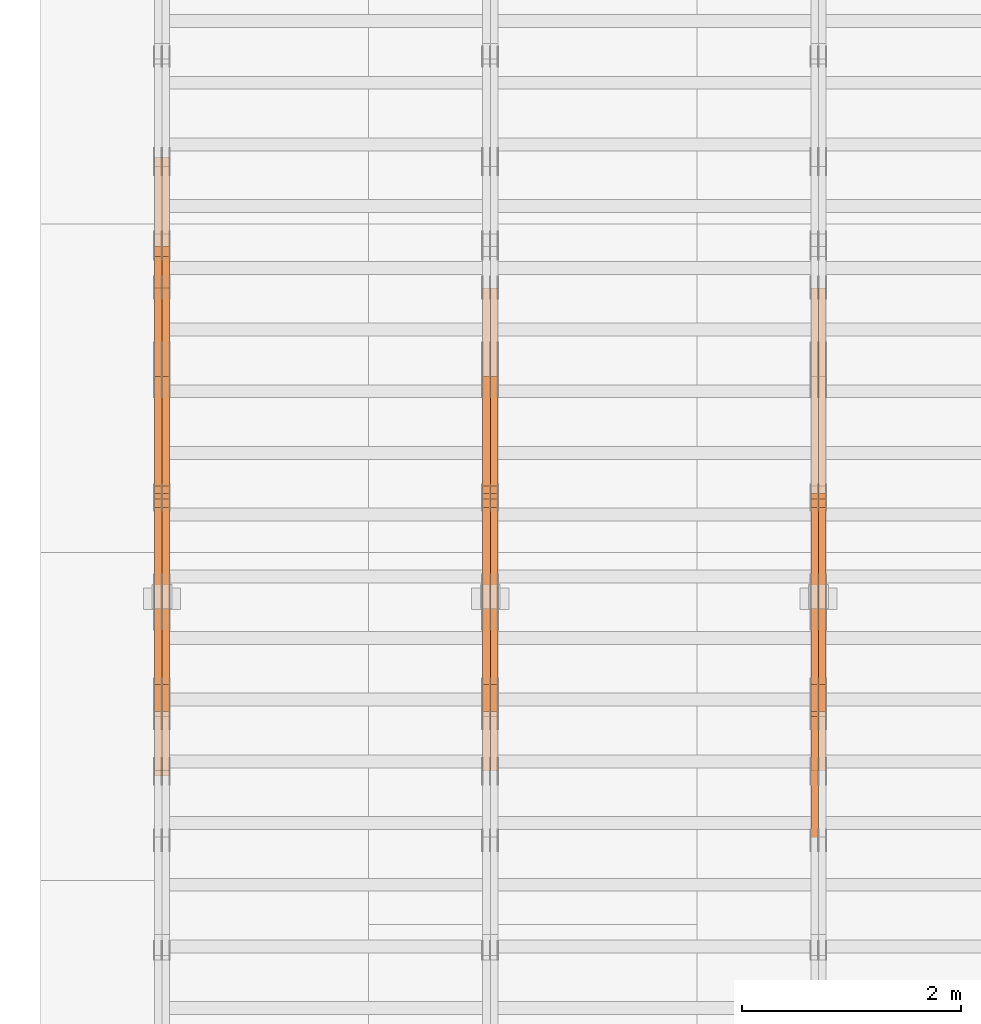
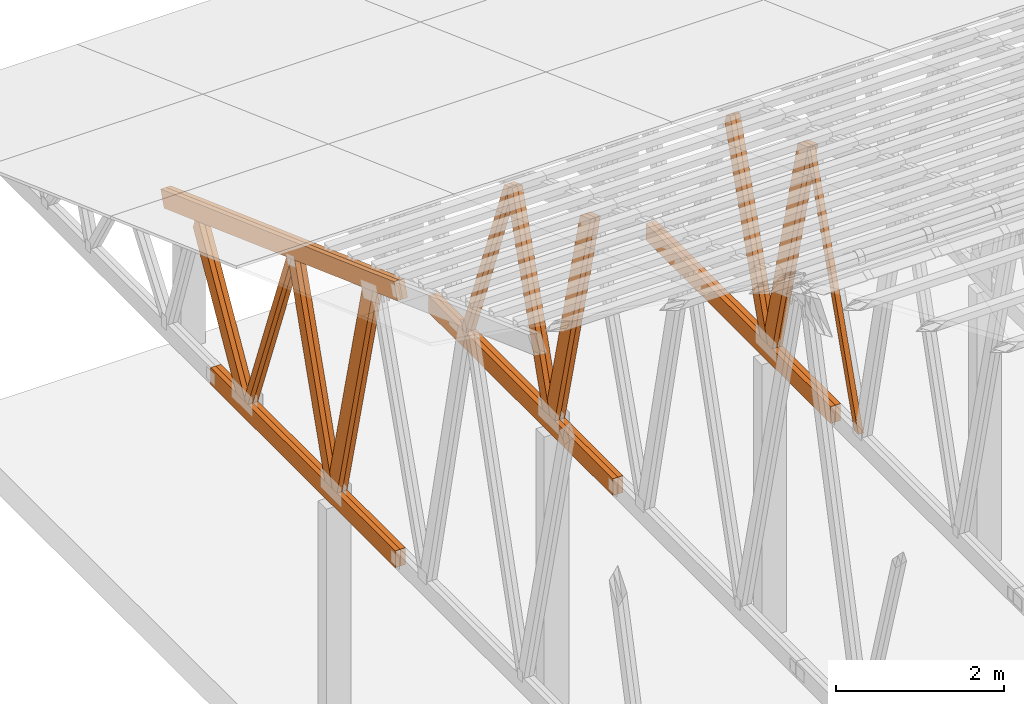
# One storey, part 32 of 189: 27 proxies.
"""IFC2X3 building model written with IfcOpenShell, lengths in millimetres."""

from ifc_helpers import new_model, entity, si_unit, converted_unit, derived_unit, direction, frame, origin, origin_2d_with_axis, place, context, subcontext, project, spatial, polyline, rectangle, outline, extrude, source, transform, mapped, material, type_object, type_shapes, element, save


model = new_model("IFC2X3")

# Units and contexts
model_context = context("Model", 3, precision=0.01, world=origin(), true_north=direction((6.12303176911189e-17, 1.0)))
body_context = subcontext(model_context, "Body", "Model", "MODEL_VIEW")
ifc_project = project(units=[si_unit("LENGTHUNIT", "METRE", prefix="MILLI"), si_unit("AREAUNIT", "SQUARE_METRE"), si_unit("VOLUMEUNIT", "CUBIC_METRE"), converted_unit("PLANEANGLEUNIT", "DEGREE", entity("IfcRatioMeasure", 0.0174532925199433), si_unit("PLANEANGLEUNIT", "RADIAN"), dimensions=[0, 0, 0, 0, 0, 0, 0]), si_unit("MASSUNIT", "GRAM", prefix="KILO"), derived_unit("MASSDENSITYUNIT", [(si_unit("MASSUNIT", "GRAM", prefix="KILO"), 1), (si_unit("LENGTHUNIT", "METRE"), -3)]), si_unit("TIMEUNIT", "SECOND"), si_unit("FREQUENCYUNIT", "HERTZ"), si_unit("THERMODYNAMICTEMPERATUREUNIT", "DEGREE_CELSIUS"), derived_unit("THERMALTRANSMITTANCEUNIT", [(si_unit("MASSUNIT", "GRAM", prefix="KILO"), 1), (si_unit("THERMODYNAMICTEMPERATUREUNIT", "KELVIN"), -1), (si_unit("TIMEUNIT", "SECOND"), -3)]), derived_unit("VOLUMETRICFLOWRATEUNIT", [(si_unit("LENGTHUNIT", "METRE"), 3), (si_unit("TIMEUNIT", "SECOND"), -1)]), si_unit("ELECTRICCURRENTUNIT", "AMPERE"), si_unit("ELECTRICVOLTAGEUNIT", "VOLT"), si_unit("POWERUNIT", "WATT"), si_unit("FORCEUNIT", "NEWTON"), si_unit("ILLUMINANCEUNIT", "LUX"), si_unit("LUMINOUSFLUXUNIT", "LUMEN"), si_unit("LUMINOUSINTENSITYUNIT", "CANDELA"), derived_unit("USERDEFINED", [(si_unit("MASSUNIT", "GRAM", prefix="KILO"), -1), (si_unit("LENGTHUNIT", "METRE"), -2), (si_unit("TIMEUNIT", "SECOND"), 3), (si_unit("LUMINOUSFLUXUNIT", "LUMEN"), 1)]), derived_unit("LINEARVELOCITYUNIT", [(si_unit("LENGTHUNIT", "METRE"), 1), (si_unit("TIMEUNIT", "SECOND"), -1)]), si_unit("PRESSUREUNIT", "PASCAL"), derived_unit("USERDEFINED", [(si_unit("LENGTHUNIT", "METRE"), -2), (si_unit("MASSUNIT", "GRAM", prefix="KILO"), 1), (si_unit("TIMEUNIT", "SECOND"), -2)])], contexts=[model_context])

# Site, building, storey
site_placement = place(None, origin())
site = spatial("IfcSite", under=ifc_project, at=site_placement, CompositionType="ELEMENT")
building_placement = place(site_placement, origin())
building = spatial("IfcBuilding", under=site, at=building_placement, CompositionType="ELEMENT")
storey_placement = place(building_placement, origin())
storey = spatial("IfcBuildingStorey", under=building, at=storey_placement, Name="Default", CompositionType="ELEMENT", Elevation=0.0)

# Proxies
ifc_material_1 = material(Name="IfcSurfaceStyle #36064")
building_element_proxy_type_1 = type_object("IfcBuildingElementProxyType", Name="T1-W7 36062", PredefinedType="NOTDEFINED", material=ifc_material_1)
shared_shape_1 = source(origin(), body_context, "Body", "SweptSolid", [
    extrude(outline(polyline([(-2189.6662270939, -47.5000140805343), (1475.30081553583, -47.5000140805343), (1473.93388518462, 0.00042343352179337), (1398.58463533215, 47.4998023637734), (-2158.15310895869, 47.4998023637734), (-2189.6662270939, -47.5000140805343)])), frame((1475.30081553583, 47.5004895824757, 0.0), z_axis=(0.0, 0.0, 1.0), x_axis=(-1.0, 0.0, 0.0)), (0.0, 0.0, 1.0), 69.9999999999998),
])
type_shapes(building_element_proxy_type_1, [shared_shape_1])
proxy_1_placement = place(building_placement, frame((6265.0, 19742.3819153401, 3693.66743808885), z_axis=(-1.0, 0.0, 0.0), x_axis=(0.0, -0.314845237923104, -0.949143021971475)))
element("IfcBuildingElementProxy", 1, at=proxy_1_placement, inside=storey, type_object=building_element_proxy_type_1, material=ifc_material_1, Name="T1-W7", context=body_context, shape_type="MappedRepresentation", body=[
    mapped(shared_shape_1, transform((0.0, 0.0, 0.0), scale=1.0)),
])
ifc_material_2 = material(Name="IfcSurfaceStyle #35866")
building_element_proxy_type_2 = type_object("IfcBuildingElementProxyType", Name="T1-W1 35864", PredefinedType="NOTDEFINED", material=ifc_material_2)
shared_shape_2 = source(origin(), body_context, "Body", "SweptSolid", [
    extrude(outline(polyline([(-1996.99427801396, -109.999889649051), (1271.09905152223, -109.999889649051), (1448.88120817726, -0.000113190727324008), (1421.70802776002, 109.999946244415), (-2144.69400944554, 109.999946244415), (-1996.99427801396, -109.999889649051)])), frame((1448.88120817726, 110.000265670598, 0.0), z_axis=(0.0, 0.0, 1.0), x_axis=(-1.0, 0.0, 0.0)), (0.0, 0.0, 1.0), 69.9999999999998),
])
type_shapes(building_element_proxy_type_2, [shared_shape_2])
proxy_2_placement = place(building_placement, frame((6335.0, 20558.6774904859, 218.61972674968), z_axis=(-1.0, 0.0, 0.0), x_axis=(0.0, -0.239819839925979, 0.970817410421691)))
element("IfcBuildingElementProxy", 2, at=proxy_2_placement, inside=storey, type_object=building_element_proxy_type_2, material=ifc_material_2, Name="T1-W1", context=body_context, shape_type="MappedRepresentation", body=[
    mapped(shared_shape_2, transform((0.0, 0.0, 0.0), scale=1.0)),
])
ifc_material_3 = material(Name="IfcSurfaceStyle #35800")
building_element_proxy_type_3 = type_object("IfcBuildingElementProxyType", Name="T1-W1 35798", PredefinedType="NOTDEFINED", material=ifc_material_3)
shared_shape_3 = source(origin(), body_context, "Body", "SweptSolid", [
    extrude(outline(polyline([(-1996.99427801396, -109.999889649051), (1271.09905152223, -109.999889649051), (1448.88120817726, -0.000113190727324008), (1421.70802776002, 109.999946244415), (-2144.69400944554, 109.999946244415), (-1996.99427801396, -109.999889649051)])), frame((1448.88120817726, 110.000265670598, 0.0), z_axis=(0.0, 0.0, 1.0), x_axis=(-1.0, 0.0, 0.0)), (0.0, 0.0, 1.0), 69.9999999999998),
])
type_shapes(building_element_proxy_type_3, [shared_shape_3])
proxy_3_placement = place(building_placement, frame((6265.0, 20558.6774904859, 218.61972674968), z_axis=(-1.0, 0.0, 0.0), x_axis=(0.0, -0.239819839925979, 0.970817410421691)))
element("IfcBuildingElementProxy", 3, at=proxy_3_placement, inside=storey, type_object=building_element_proxy_type_3, material=ifc_material_3, Name="T1-W1", context=body_context, shape_type="MappedRepresentation", body=[
    mapped(shared_shape_3, transform((0.0, 0.0, 0.0), scale=1.0)),
])
ifc_material_4 = material(Name="IfcSurfaceStyle #35602")
building_element_proxy_type_4 = type_object("IfcBuildingElementProxyType", Name="T1-W4 35600", PredefinedType="NOTDEFINED", material=ifc_material_4)
shared_shape_4 = source(origin(), body_context, "Body", "SweptSolid", [
    extrude(outline(polyline([(-1742.90513395849, -84.9997422414737), (1181.3544167489, -84.9997422414737), (1178.19398821251, -0.000208932978430543), (1071.44989130457, 84.999846707963), (-1688.09316230749, 84.999846707963), (-1742.90513395849, -84.9997422414737)])), frame((1181.35452116422, 84.999886337523, 0.0), z_axis=(0.0, 0.0, 1.0), x_axis=(-1.0, 0.0, 0.0)), (0.0, 0.0, 1.0), 69.9999999999998),
])
type_shapes(building_element_proxy_type_4, [shared_shape_4])
proxy_4_placement = place(building_placement, frame((6335.0, 21724.6281517871, 2976.00232464744), z_axis=(-1.0, 0.0, 0.0), x_axis=(0.0, -0.306868406216495, -0.951751953644514)))
element("IfcBuildingElementProxy", 4, at=proxy_4_placement, inside=storey, type_object=building_element_proxy_type_4, material=ifc_material_4, Name="T1-W4", context=body_context, shape_type="MappedRepresentation", body=[
    mapped(shared_shape_4, transform((0.0, 0.0, 0.0), scale=1.0)),
])
ifc_material_5 = material(Name="IfcSurfaceStyle #35536")
building_element_proxy_type_5 = type_object("IfcBuildingElementProxyType", Name="T1-W4 35534", PredefinedType="NOTDEFINED", material=ifc_material_5)
shared_shape_5 = source(origin(), body_context, "Body", "SweptSolid", [
    extrude(outline(polyline([(-1742.90513395849, -84.9997422414737), (1181.3544167489, -84.9997422414737), (1178.19398821251, -0.000208932978430543), (1071.44989130457, 84.999846707963), (-1688.09316230749, 84.999846707963), (-1742.90513395849, -84.9997422414737)])), frame((1181.35452116422, 84.999886337523, 0.0), z_axis=(0.0, 0.0, 1.0), x_axis=(-1.0, 0.0, 0.0)), (0.0, 0.0, 1.0), 69.9999999999998),
])
type_shapes(building_element_proxy_type_5, [shared_shape_5])
proxy_5_placement = place(building_placement, frame((6265.0, 21724.6281517871, 2976.00232464744), z_axis=(-1.0, 0.0, 0.0), x_axis=(0.0, -0.306868406216495, -0.951751953644514)))
element("IfcBuildingElementProxy", 5, at=proxy_5_placement, inside=storey, type_object=building_element_proxy_type_5, material=ifc_material_5, Name="T1-W4", context=body_context, shape_type="MappedRepresentation", body=[
    mapped(shared_shape_5, transform((0.0, 0.0, 0.0), scale=1.0)),
])
ifc_material_6 = material(Name="IfcSurfaceStyle #32998")
building_element_proxy_type_6 = type_object("IfcBuildingElementProxyType", Name="T1-B4 32996", PredefinedType="NOTDEFINED", material=ifc_material_6)
shared_shape_6 = source(origin(), body_context, "Body", "SweptSolid", [
    extrude(rectangle(XDim=4408.2412109375, YDim=245.000000000001, at=origin_2d_with_axis()), frame((2204.12060546875, 122.5, 0.0), z_axis=(0.0, 0.0, 1.0), x_axis=(-1.0, 0.0, 0.0)), (0.0, 0.0, 1.0), 69.9999999999997),
])
type_shapes(building_element_proxy_type_6, [shared_shape_6])
proxy_6_placement = place(building_placement, frame((6335.0, 19161.7587890625, 245.0), z_axis=(-1.0, 0.0, 0.0), x_axis=(0.0, 1.0, 0.0)))
element("IfcBuildingElementProxy", 6, at=proxy_6_placement, inside=storey, type_object=building_element_proxy_type_6, material=ifc_material_6, Name="T1-B4", context=body_context, shape_type="MappedRepresentation", body=[
    mapped(shared_shape_6, transform((0.0, 0.0, 0.0), scale=1.0)),
])
ifc_material_7 = material(Name="IfcSurfaceStyle #32941")
building_element_proxy_type_7 = type_object("IfcBuildingElementProxyType", Name="T1-B4 32939", PredefinedType="NOTDEFINED", material=ifc_material_7)
shared_shape_7 = source(origin(), body_context, "Body", "SweptSolid", [
    extrude(rectangle(XDim=4408.2412109375, YDim=245.000000000001, at=origin_2d_with_axis()), frame((2204.12060546875, 122.5, 0.0), z_axis=(0.0, 0.0, 1.0), x_axis=(-1.0, 0.0, 0.0)), (0.0, 0.0, 1.0), 69.9999999999997),
])
type_shapes(building_element_proxy_type_7, [shared_shape_7])
proxy_7_placement = place(building_placement, frame((6265.0, 19161.7587890625, 245.0), z_axis=(-1.0, 0.0, 0.0), x_axis=(0.0, 1.0, 0.0)))
element("IfcBuildingElementProxy", 7, at=proxy_7_placement, inside=storey, type_object=building_element_proxy_type_7, material=ifc_material_7, Name="T1-B4", context=body_context, shape_type="MappedRepresentation", body=[
    mapped(shared_shape_7, transform((0.0, 0.0, 0.0), scale=1.0)),
])
ifc_material_8 = material(Name="IfcSurfaceStyle #20076")
building_element_proxy_type_8 = type_object("IfcBuildingElementProxyType", Name="T1-W1 20074", PredefinedType="NOTDEFINED", material=ifc_material_8)
shared_shape_8 = source(origin(), body_context, "Body", "SweptSolid", [
    extrude(outline(polyline([(-1996.99427801396, -109.999889649051), (1271.09905152223, -109.999889649051), (1448.88120817726, -0.000113190727324008), (1421.70802776002, 109.999946244415), (-2144.69400944554, 109.999946244415), (-1996.99427801396, -109.999889649051)])), frame((1448.88120817726, 110.000265670598, 0.0), z_axis=(0.0, 0.0, 1.0), x_axis=(-1.0, 0.0, 0.0)), (0.0, 0.0, 1.0), 69.9999999999998),
])
type_shapes(building_element_proxy_type_8, [shared_shape_8])
proxy_8_placement = place(building_placement, frame((3335.0, 20558.6774904859, 218.61972674968), z_axis=(-1.0, 0.0, 0.0), x_axis=(0.0, -0.239819839925979, 0.970817410421691)))
element("IfcBuildingElementProxy", 8, at=proxy_8_placement, inside=storey, type_object=building_element_proxy_type_8, material=ifc_material_8, Name="T1-W1", context=body_context, shape_type="MappedRepresentation", body=[
    mapped(shared_shape_8, transform((0.0, 0.0, 0.0), scale=1.0)),
])
ifc_material_9 = material(Name="IfcSurfaceStyle #20010")
building_element_proxy_type_9 = type_object("IfcBuildingElementProxyType", Name="T1-W1 20008", PredefinedType="NOTDEFINED", material=ifc_material_9)
shared_shape_9 = source(origin(), body_context, "Body", "SweptSolid", [
    extrude(outline(polyline([(-1996.99427801396, -109.999889649051), (1271.09905152223, -109.999889649051), (1448.88120817726, -0.000113190727324008), (1421.70802776002, 109.999946244415), (-2144.69400944554, 109.999946244415), (-1996.99427801396, -109.999889649051)])), frame((1448.88120817726, 110.000265670598, 0.0), z_axis=(0.0, 0.0, 1.0), x_axis=(-1.0, 0.0, 0.0)), (0.0, 0.0, 1.0), 69.9999999999998),
])
type_shapes(building_element_proxy_type_9, [shared_shape_9])
proxy_9_placement = place(building_placement, frame((3265.0, 20558.6774904859, 218.61972674968), z_axis=(-1.0, 0.0, 0.0), x_axis=(0.0, -0.239819839925979, 0.970817410421691)))
element("IfcBuildingElementProxy", 9, at=proxy_9_placement, inside=storey, type_object=building_element_proxy_type_9, material=ifc_material_9, Name="T1-W1", context=body_context, shape_type="MappedRepresentation", body=[
    mapped(shared_shape_9, transform((0.0, 0.0, 0.0), scale=1.0)),
])
ifc_material_10 = material(Name="IfcSurfaceStyle #19812")
building_element_proxy_type_10 = type_object("IfcBuildingElementProxyType", Name="T1-W4 19810", PredefinedType="NOTDEFINED", material=ifc_material_10)
shared_shape_10 = source(origin(), body_context, "Body", "SweptSolid", [
    extrude(outline(polyline([(-1742.90513395849, -84.9997422414737), (1181.3544167489, -84.9997422414737), (1178.19398821251, -0.000208932978430543), (1071.44989130457, 84.999846707963), (-1688.09316230749, 84.999846707963), (-1742.90513395849, -84.9997422414737)])), frame((1181.35452116422, 84.999886337523, 0.0), z_axis=(0.0, 0.0, 1.0), x_axis=(-1.0, 0.0, 0.0)), (0.0, 0.0, 1.0), 69.9999999999998),
])
type_shapes(building_element_proxy_type_10, [shared_shape_10])
proxy_10_placement = place(building_placement, frame((3335.0, 21724.6281517871, 2976.00232464744), z_axis=(-1.0, 0.0, 0.0), x_axis=(0.0, -0.306868406216495, -0.951751953644514)))
element("IfcBuildingElementProxy", 10, at=proxy_10_placement, inside=storey, type_object=building_element_proxy_type_10, material=ifc_material_10, Name="T1-W4", context=body_context, shape_type="MappedRepresentation", body=[
    mapped(shared_shape_10, transform((0.0, 0.0, 0.0), scale=1.0)),
])
ifc_material_11 = material(Name="IfcSurfaceStyle #19746")
building_element_proxy_type_11 = type_object("IfcBuildingElementProxyType", Name="T1-W4 19744", PredefinedType="NOTDEFINED", material=ifc_material_11)
shared_shape_11 = source(origin(), body_context, "Body", "SweptSolid", [
    extrude(outline(polyline([(-1742.90513395849, -84.9997422414737), (1181.3544167489, -84.9997422414737), (1178.19398821251, -0.000208932978430543), (1071.44989130457, 84.999846707963), (-1688.09316230749, 84.999846707963), (-1742.90513395849, -84.9997422414737)])), frame((1181.35452116422, 84.999886337523, 0.0), z_axis=(0.0, 0.0, 1.0), x_axis=(-1.0, 0.0, 0.0)), (0.0, 0.0, 1.0), 69.9999999999998),
])
type_shapes(building_element_proxy_type_11, [shared_shape_11])
proxy_11_placement = place(building_placement, frame((3265.0, 21724.6281517871, 2976.00232464744), z_axis=(-1.0, 0.0, 0.0), x_axis=(0.0, -0.306868406216495, -0.951751953644514)))
element("IfcBuildingElementProxy", 11, at=proxy_11_placement, inside=storey, type_object=building_element_proxy_type_11, material=ifc_material_11, Name="T1-W4", context=body_context, shape_type="MappedRepresentation", body=[
    mapped(shared_shape_11, transform((0.0, 0.0, 0.0), scale=1.0)),
])
ifc_material_12 = material(Name="IfcSurfaceStyle #19548")
building_element_proxy_type_12 = type_object("IfcBuildingElementProxyType", Name="T1-W8 19546", PredefinedType="NOTDEFINED", material=ifc_material_12)
shared_shape_12 = source(origin(), body_context, "Body", "SweptSolid", [
    extrude(outline(polyline([(-1700.10906247918, -47.4998559987011), (1140.60243146647, -47.4998559987011), (1179.56122089033, 0.000120838919977206), (1161.65086478184, 47.4997955792411), (-1781.70545465947, 47.4997955792411), (-1700.10906247918, -47.4998559987011)])), frame((1179.56128464708, 47.5000634692093, 0.0), z_axis=(0.0, 0.0, 1.0), x_axis=(-1.0, 0.0, 0.0)), (0.0, 0.0, 1.0), 69.9999999999998),
])
type_shapes(building_element_proxy_type_12, [shared_shape_12])
proxy_12_placement = place(building_placement, frame((3335.0, 22687.5385403115, 228.241249073207), z_axis=(-1.0, 0.0, 0.0), x_axis=(0.0, -0.352814979177604, 0.93569310698963)))
element("IfcBuildingElementProxy", 12, at=proxy_12_placement, inside=storey, type_object=building_element_proxy_type_12, material=ifc_material_12, Name="T1-W8", context=body_context, shape_type="MappedRepresentation", body=[
    mapped(shared_shape_12, transform((0.0, 0.0, 0.0), scale=1.0)),
])
ifc_material_13 = material(Name="IfcSurfaceStyle #19482")
building_element_proxy_type_13 = type_object("IfcBuildingElementProxyType", Name="T1-W8 19480", PredefinedType="NOTDEFINED", material=ifc_material_13)
shared_shape_13 = source(origin(), body_context, "Body", "SweptSolid", [
    extrude(outline(polyline([(-1700.10906247918, -47.4998559987011), (1140.60243146647, -47.4998559987011), (1179.56122089033, 0.000120838919977206), (1161.65086478184, 47.4997955792411), (-1781.70545465947, 47.4997955792411), (-1700.10906247918, -47.4998559987011)])), frame((1179.56128464708, 47.5000634692093, 0.0), z_axis=(0.0, 0.0, 1.0), x_axis=(-1.0, 0.0, 0.0)), (0.0, 0.0, 1.0), 69.9999999999998),
])
type_shapes(building_element_proxy_type_13, [shared_shape_13])
proxy_13_placement = place(building_placement, frame((3265.0, 22687.5385403115, 228.241249073207), z_axis=(-1.0, 0.0, 0.0), x_axis=(0.0, -0.352814979177604, 0.93569310698963)))
element("IfcBuildingElementProxy", 13, at=proxy_13_placement, inside=storey, type_object=building_element_proxy_type_13, material=ifc_material_13, Name="T1-W8", context=body_context, shape_type="MappedRepresentation", body=[
    mapped(shared_shape_13, transform((0.0, 0.0, 0.0), scale=1.0)),
])
ifc_material_14 = material(Name="IfcSurfaceStyle #17208")
building_element_proxy_type_14 = type_object("IfcBuildingElementProxyType", Name="T1-B4 17206", PredefinedType="NOTDEFINED", material=ifc_material_14)
shared_shape_14 = source(origin(), body_context, "Body", "SweptSolid", [
    extrude(rectangle(XDim=4408.2412109375, YDim=245.000000000001, at=origin_2d_with_axis()), frame((2204.12060546875, 122.5, 0.0), z_axis=(0.0, 0.0, 1.0), x_axis=(-1.0, 0.0, 0.0)), (0.0, 0.0, 1.0), 69.9999999999997),
])
type_shapes(building_element_proxy_type_14, [shared_shape_14])
proxy_14_placement = place(building_placement, frame((3335.0, 19161.7587890625, 245.0), z_axis=(-1.0, 0.0, 0.0), x_axis=(0.0, 1.0, 0.0)))
element("IfcBuildingElementProxy", 14, at=proxy_14_placement, inside=storey, type_object=building_element_proxy_type_14, material=ifc_material_14, Name="T1-B4", context=body_context, shape_type="MappedRepresentation", body=[
    mapped(shared_shape_14, transform((0.0, 0.0, 0.0), scale=1.0)),
])
ifc_material_15 = material(Name="IfcSurfaceStyle #17151")
building_element_proxy_type_15 = type_object("IfcBuildingElementProxyType", Name="T1-B4 17149", PredefinedType="NOTDEFINED", material=ifc_material_15)
shared_shape_15 = source(origin(), body_context, "Body", "SweptSolid", [
    extrude(rectangle(XDim=4408.2412109375, YDim=245.000000000001, at=origin_2d_with_axis()), frame((2204.12060546875, 122.5, 0.0), z_axis=(0.0, 0.0, 1.0), x_axis=(-1.0, 0.0, 0.0)), (0.0, 0.0, 1.0), 69.9999999999997),
])
type_shapes(building_element_proxy_type_15, [shared_shape_15])
proxy_15_placement = place(building_placement, frame((3265.0, 19161.7587890625, 245.0), z_axis=(-1.0, 0.0, 0.0), x_axis=(0.0, 1.0, 0.0)))
element("IfcBuildingElementProxy", 15, at=proxy_15_placement, inside=storey, type_object=building_element_proxy_type_15, material=ifc_material_15, Name="T1-B4", context=body_context, shape_type="MappedRepresentation", body=[
    mapped(shared_shape_15, transform((0.0, 0.0, 0.0), scale=1.0)),
])
ifc_material_16 = material(Name="IfcSurfaceStyle #4283")
building_element_proxy_type_16 = type_object("IfcBuildingElementProxyType", Name="T1-W1 4281", PredefinedType="NOTDEFINED", material=ifc_material_16)
shared_shape_16 = source(origin(), body_context, "Body", "SweptSolid", [
    extrude(outline(polyline([(-1996.99427801396, -109.999889649051), (1271.09905152223, -109.999889649051), (1448.88120817726, -0.000113190727324008), (1421.70802776002, 109.999946244415), (-2144.69400944554, 109.999946244415), (-1996.99427801396, -109.999889649051)])), frame((1448.88120817726, 110.000265670598, 0.0), z_axis=(0.0, 0.0, 1.0), x_axis=(-1.0, 0.0, 0.0)), (0.0, 0.0, 1.0), 69.9999999999998),
])
type_shapes(building_element_proxy_type_16, [shared_shape_16])
proxy_16_placement = place(building_placement, frame((335.0, 20558.6774904859, 218.61972674968), z_axis=(-1.0, 0.0, 0.0), x_axis=(0.0, -0.239819839925979, 0.970817410421691)))
element("IfcBuildingElementProxy", 16, at=proxy_16_placement, inside=storey, type_object=building_element_proxy_type_16, material=ifc_material_16, Name="T1-W1", context=body_context, shape_type="MappedRepresentation", body=[
    mapped(shared_shape_16, transform((0.0, 0.0, 0.0), scale=1.0)),
])
ifc_material_17 = material(Name="IfcSurfaceStyle #4217")
building_element_proxy_type_17 = type_object("IfcBuildingElementProxyType", Name="T1-W1 4215", PredefinedType="NOTDEFINED", material=ifc_material_17)
shared_shape_17 = source(origin(), body_context, "Body", "SweptSolid", [
    extrude(outline(polyline([(-1996.99427801396, -109.999889649051), (1271.09905152223, -109.999889649051), (1448.88120817726, -0.000113190727324008), (1421.70802776002, 109.999946244415), (-2144.69400944554, 109.999946244415), (-1996.99427801396, -109.999889649051)])), frame((1448.88120817726, 110.000265670598, 0.0), z_axis=(0.0, 0.0, 1.0), x_axis=(-1.0, 0.0, 0.0)), (0.0, 0.0, 1.0), 69.9999999999998),
])
type_shapes(building_element_proxy_type_17, [shared_shape_17])
proxy_17_placement = place(building_placement, frame((265.0, 20558.6774904859, 218.61972674968), z_axis=(-1.0, 0.0, 0.0), x_axis=(0.0, -0.239819839925979, 0.970817410421691)))
element("IfcBuildingElementProxy", 17, at=proxy_17_placement, inside=storey, type_object=building_element_proxy_type_17, material=ifc_material_17, Name="T1-W1", context=body_context, shape_type="MappedRepresentation", body=[
    mapped(shared_shape_17, transform((0.0, 0.0, 0.0), scale=1.0)),
])
ifc_material_18 = material(Name="IfcSurfaceStyle #4019")
building_element_proxy_type_18 = type_object("IfcBuildingElementProxyType", Name="T1-W4 4017", PredefinedType="NOTDEFINED", material=ifc_material_18)
shared_shape_18 = source(origin(), body_context, "Body", "SweptSolid", [
    extrude(outline(polyline([(-1742.90513395849, -84.9997422414737), (1181.3544167489, -84.9997422414737), (1178.19398821251, -0.000208932978430543), (1071.44989130457, 84.999846707963), (-1688.09316230749, 84.999846707963), (-1742.90513395849, -84.9997422414737)])), frame((1181.35452116422, 84.999886337523, 0.0), z_axis=(0.0, 0.0, 1.0), x_axis=(-1.0, 0.0, 0.0)), (0.0, 0.0, 1.0), 69.9999999999998),
])
type_shapes(building_element_proxy_type_18, [shared_shape_18])
proxy_18_placement = place(building_placement, frame((335.0, 21724.6281517871, 2976.00232464744), z_axis=(-1.0, 0.0, 0.0), x_axis=(0.0, -0.306868406216495, -0.951751953644514)))
element("IfcBuildingElementProxy", 18, at=proxy_18_placement, inside=storey, type_object=building_element_proxy_type_18, material=ifc_material_18, Name="T1-W4", context=body_context, shape_type="MappedRepresentation", body=[
    mapped(shared_shape_18, transform((0.0, 0.0, 0.0), scale=1.0)),
])
ifc_material_19 = material(Name="IfcSurfaceStyle #3953")
building_element_proxy_type_19 = type_object("IfcBuildingElementProxyType", Name="T1-W4 3951", PredefinedType="NOTDEFINED", material=ifc_material_19)
shared_shape_19 = source(origin(), body_context, "Body", "SweptSolid", [
    extrude(outline(polyline([(-1742.90513395849, -84.9997422414737), (1181.3544167489, -84.9997422414737), (1178.19398821251, -0.000208932978430543), (1071.44989130457, 84.999846707963), (-1688.09316230749, 84.999846707963), (-1742.90513395849, -84.9997422414737)])), frame((1181.35452116422, 84.999886337523, 0.0), z_axis=(0.0, 0.0, 1.0), x_axis=(-1.0, 0.0, 0.0)), (0.0, 0.0, 1.0), 69.9999999999998),
])
type_shapes(building_element_proxy_type_19, [shared_shape_19])
proxy_19_placement = place(building_placement, frame((265.0, 21724.6281517871, 2976.00232464744), z_axis=(-1.0, 0.0, 0.0), x_axis=(0.0, -0.306868406216495, -0.951751953644514)))
element("IfcBuildingElementProxy", 19, at=proxy_19_placement, inside=storey, type_object=building_element_proxy_type_19, material=ifc_material_19, Name="T1-W4", context=body_context, shape_type="MappedRepresentation", body=[
    mapped(shared_shape_19, transform((0.0, 0.0, 0.0), scale=1.0)),
])
ifc_material_20 = material(Name="IfcSurfaceStyle #3755")
building_element_proxy_type_20 = type_object("IfcBuildingElementProxyType", Name="T1-W8 3753", PredefinedType="NOTDEFINED", material=ifc_material_20)
shared_shape_20 = source(origin(), body_context, "Body", "SweptSolid", [
    extrude(outline(polyline([(-1700.10906247918, -47.4998559987011), (1140.60243146647, -47.4998559987011), (1179.56122089033, 0.000120838919977206), (1161.65086478184, 47.4997955792411), (-1781.70545465947, 47.4997955792411), (-1700.10906247918, -47.4998559987011)])), frame((1179.56128464708, 47.5000634692093, 0.0), z_axis=(0.0, 0.0, 1.0), x_axis=(-1.0, 0.0, 0.0)), (0.0, 0.0, 1.0), 69.9999999999998),
])
type_shapes(building_element_proxy_type_20, [shared_shape_20])
proxy_20_placement = place(building_placement, frame((335.0, 22687.5385403115, 228.241249073207), z_axis=(-1.0, 0.0, 0.0), x_axis=(0.0, -0.352814979177604, 0.93569310698963)))
element("IfcBuildingElementProxy", 20, at=proxy_20_placement, inside=storey, type_object=building_element_proxy_type_20, material=ifc_material_20, Name="T1-W8", context=body_context, shape_type="MappedRepresentation", body=[
    mapped(shared_shape_20, transform((0.0, 0.0, 0.0), scale=1.0)),
])
ifc_material_21 = material(Name="IfcSurfaceStyle #3689")
building_element_proxy_type_21 = type_object("IfcBuildingElementProxyType", Name="T1-W8 3687", PredefinedType="NOTDEFINED", material=ifc_material_21)
shared_shape_21 = source(origin(), body_context, "Body", "SweptSolid", [
    extrude(outline(polyline([(-1700.10906247918, -47.4998559987011), (1140.60243146647, -47.4998559987011), (1179.56122089033, 0.000120838919977206), (1161.65086478184, 47.4997955792411), (-1781.70545465947, 47.4997955792411), (-1700.10906247918, -47.4998559987011)])), frame((1179.56128464708, 47.5000634692093, 0.0), z_axis=(0.0, 0.0, 1.0), x_axis=(-1.0, 0.0, 0.0)), (0.0, 0.0, 1.0), 69.9999999999998),
])
type_shapes(building_element_proxy_type_21, [shared_shape_21])
proxy_21_placement = place(building_placement, frame((265.0, 22687.5385403115, 228.241249073207), z_axis=(-1.0, 0.0, 0.0), x_axis=(0.0, -0.352814979177604, 0.93569310698963)))
element("IfcBuildingElementProxy", 21, at=proxy_21_placement, inside=storey, type_object=building_element_proxy_type_21, material=ifc_material_21, Name="T1-W8", context=body_context, shape_type="MappedRepresentation", body=[
    mapped(shared_shape_21, transform((0.0, 0.0, 0.0), scale=1.0)),
])
ifc_material_22 = material(Name="IfcSurfaceStyle #3491")
building_element_proxy_type_22 = type_object("IfcBuildingElementProxyType", Name="T1-W2 3489", PredefinedType="NOTDEFINED", material=ifc_material_22)
shared_shape_22 = source(origin(), body_context, "Body", "SweptSolid", [
    extrude(outline(polyline([(-1361.89144606429, -97.5000598486876), (887.613245225805, -97.5000598486876), (904.774262962339, 0.000302345139042259), (818.892339969004, 97.4999086761182), (-1249.38840209286, 97.4999086761182), (-1361.89144606429, -97.5000598486876)])), frame((904.774262962339, 97.5000966763391, 0.0), z_axis=(0.0, 0.0, 1.0), x_axis=(-1.0, 0.0, 0.0)), (0.0, 0.0, 1.0), 69.9999999999999),
])
type_shapes(building_element_proxy_type_22, [shared_shape_22])
proxy_22_placement = place(building_placement, frame((335.0, 24033.6159173732, 2110.89189244614), z_axis=(-1.0, 0.0, 0.0), x_axis=(0.0, -0.5, -0.866025403784439)))
element("IfcBuildingElementProxy", 22, at=proxy_22_placement, inside=storey, type_object=building_element_proxy_type_22, material=ifc_material_22, Name="T1-W2", context=body_context, shape_type="MappedRepresentation", body=[
    mapped(shared_shape_22, transform((0.0, 0.0, 0.0), scale=1.0)),
])
ifc_material_23 = material(Name="IfcSurfaceStyle #3425")
building_element_proxy_type_23 = type_object("IfcBuildingElementProxyType", Name="T1-W2 3423", PredefinedType="NOTDEFINED", material=ifc_material_23)
shared_shape_23 = source(origin(), body_context, "Body", "SweptSolid", [
    extrude(outline(polyline([(-1361.89144606429, -97.5000598486876), (887.613245225805, -97.5000598486876), (904.774262962339, 0.000302345139042259), (818.892339969004, 97.4999086761182), (-1249.38840209286, 97.4999086761182), (-1361.89144606429, -97.5000598486876)])), frame((904.774262962339, 97.5000966763391, 0.0), z_axis=(0.0, 0.0, 1.0), x_axis=(-1.0, 0.0, 0.0)), (0.0, 0.0, 1.0), 69.9999999999999),
])
type_shapes(building_element_proxy_type_23, [shared_shape_23])
proxy_23_placement = place(building_placement, frame((265.0, 24033.6159173732, 2110.89189244614), z_axis=(-1.0, 0.0, 0.0), x_axis=(0.0, -0.5, -0.866025403784439)))
element("IfcBuildingElementProxy", 23, at=proxy_23_placement, inside=storey, type_object=building_element_proxy_type_23, material=ifc_material_23, Name="T1-W2", context=body_context, shape_type="MappedRepresentation", body=[
    mapped(shared_shape_23, transform((0.0, 0.0, 0.0), scale=1.0)),
])
ifc_material_24 = material(Name="IfcSurfaceStyle #1415")
building_element_proxy_type_24 = type_object("IfcBuildingElementProxyType", Name="T1-B4 1413", PredefinedType="NOTDEFINED", material=ifc_material_24)
shared_shape_24 = source(origin(), body_context, "Body", "SweptSolid", [
    extrude(rectangle(XDim=4408.2412109375, YDim=245.000000000001, at=origin_2d_with_axis()), frame((2204.12060546875, 122.5, 0.0), z_axis=(0.0, 0.0, 1.0), x_axis=(-1.0, 0.0, 0.0)), (0.0, 0.0, 1.0), 69.9999999999997),
])
type_shapes(building_element_proxy_type_24, [shared_shape_24])
proxy_24_placement = place(building_placement, frame((335.0, 19161.7587890625, 245.0), z_axis=(-1.0, 0.0, 0.0), x_axis=(0.0, 1.0, 0.0)))
element("IfcBuildingElementProxy", 24, at=proxy_24_placement, inside=storey, type_object=building_element_proxy_type_24, material=ifc_material_24, Name="T1-B4", context=body_context, shape_type="MappedRepresentation", body=[
    mapped(shared_shape_24, transform((0.0, 0.0, 0.0), scale=1.0)),
])
ifc_material_25 = material(Name="IfcSurfaceStyle #1358")
building_element_proxy_type_25 = type_object("IfcBuildingElementProxyType", Name="T1-B4 1356", PredefinedType="NOTDEFINED", material=ifc_material_25)
shared_shape_25 = source(origin(), body_context, "Body", "SweptSolid", [
    extrude(rectangle(XDim=4408.2412109375, YDim=245.000000000001, at=origin_2d_with_axis()), frame((2204.12060546875, 122.5, 0.0), z_axis=(0.0, 0.0, 1.0), x_axis=(-1.0, 0.0, 0.0)), (0.0, 0.0, 1.0), 69.9999999999997),
])
type_shapes(building_element_proxy_type_25, [shared_shape_25])
proxy_25_placement = place(building_placement, frame((265.0, 19161.7587890625, 245.0), z_axis=(-1.0, 0.0, 0.0), x_axis=(0.0, 1.0, 0.0)))
element("IfcBuildingElementProxy", 25, at=proxy_25_placement, inside=storey, type_object=building_element_proxy_type_25, material=ifc_material_25, Name="T1-B4", context=body_context, shape_type="MappedRepresentation", body=[
    mapped(shared_shape_25, transform((0.0, 0.0, 0.0), scale=1.0)),
])
ifc_material_26 = material(Name="IfcSurfaceStyle #371")
building_element_proxy_type_26 = type_object("IfcBuildingElementProxyType", Name="T1-T1 369", PredefinedType="NOTDEFINED", material=ifc_material_26)
shared_shape_26 = source(origin(), body_context, "Body", "SweptSolid", [
    extrude(outline(polyline([(-2964.99982426074, -122.499947708046), (2964.99981923522, -122.499947708046), (2964.99984513599, 122.499947708046), (-2964.99984011047, 122.499947708046), (-2964.99982426074, -122.499947708046)])), frame((2964.99984513599, 122.499998966405, 0.0), z_axis=(0.0, 0.0, 1.0), x_axis=(-1.0, 0.0, 0.0)), (0.0, 0.0, 1.0), 69.9999999999996),
])
type_shapes(building_element_proxy_type_26, [shared_shape_26])
proxy_26_placement = place(building_placement, frame((335.0, 24681.3398262186, 1893.12531804384), z_axis=(-1.0, 0.0, 0.0), x_axis=(0.0, -0.939692620785908, 0.342020143325669)))
element("IfcBuildingElementProxy", 26, at=proxy_26_placement, inside=storey, type_object=building_element_proxy_type_26, material=ifc_material_26, Name="T1-T1", context=body_context, shape_type="MappedRepresentation", body=[
    mapped(shared_shape_26, transform((0.0, 0.0, 0.0), scale=1.0)),
])
ifc_material_27 = material(Name="IfcSurfaceStyle #314")
building_element_proxy_type_27 = type_object("IfcBuildingElementProxyType", Name="T1-T1 312", PredefinedType="NOTDEFINED", material=ifc_material_27)
shared_shape_27 = source(origin(), body_context, "Body", "SweptSolid", [
    extrude(outline(polyline([(-2964.99982426074, -122.499947708046), (2964.99981923522, -122.499947708046), (2964.99984513599, 122.499947708046), (-2964.99984011047, 122.499947708046), (-2964.99982426074, -122.499947708046)])), frame((2964.99984513599, 122.499998966405, 0.0), z_axis=(0.0, 0.0, 1.0), x_axis=(-1.0, 0.0, 0.0)), (0.0, 0.0, 1.0), 69.9999999999996),
])
type_shapes(building_element_proxy_type_27, [shared_shape_27])
proxy_27_placement = place(building_placement, frame((265.0, 24681.3398262186, 1893.12531804384), z_axis=(-1.0, 0.0, 0.0), x_axis=(0.0, -0.939692620785908, 0.342020143325669)))
element("IfcBuildingElementProxy", 27, at=proxy_27_placement, inside=storey, type_object=building_element_proxy_type_27, material=ifc_material_27, Name="T1-T1", context=body_context, shape_type="MappedRepresentation", body=[
    mapped(shared_shape_27, transform((0.0, 0.0, 0.0), scale=1.0)),
])

save(model, "model.ifc")
